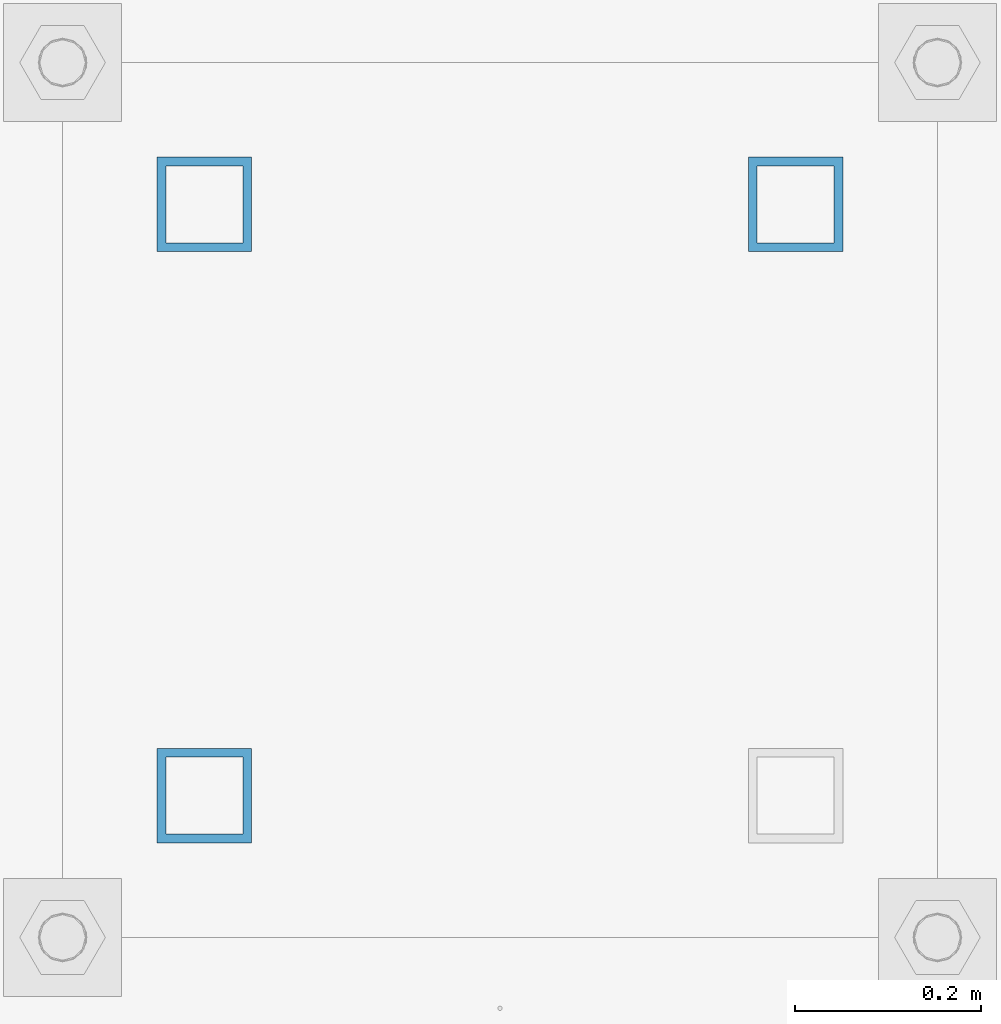
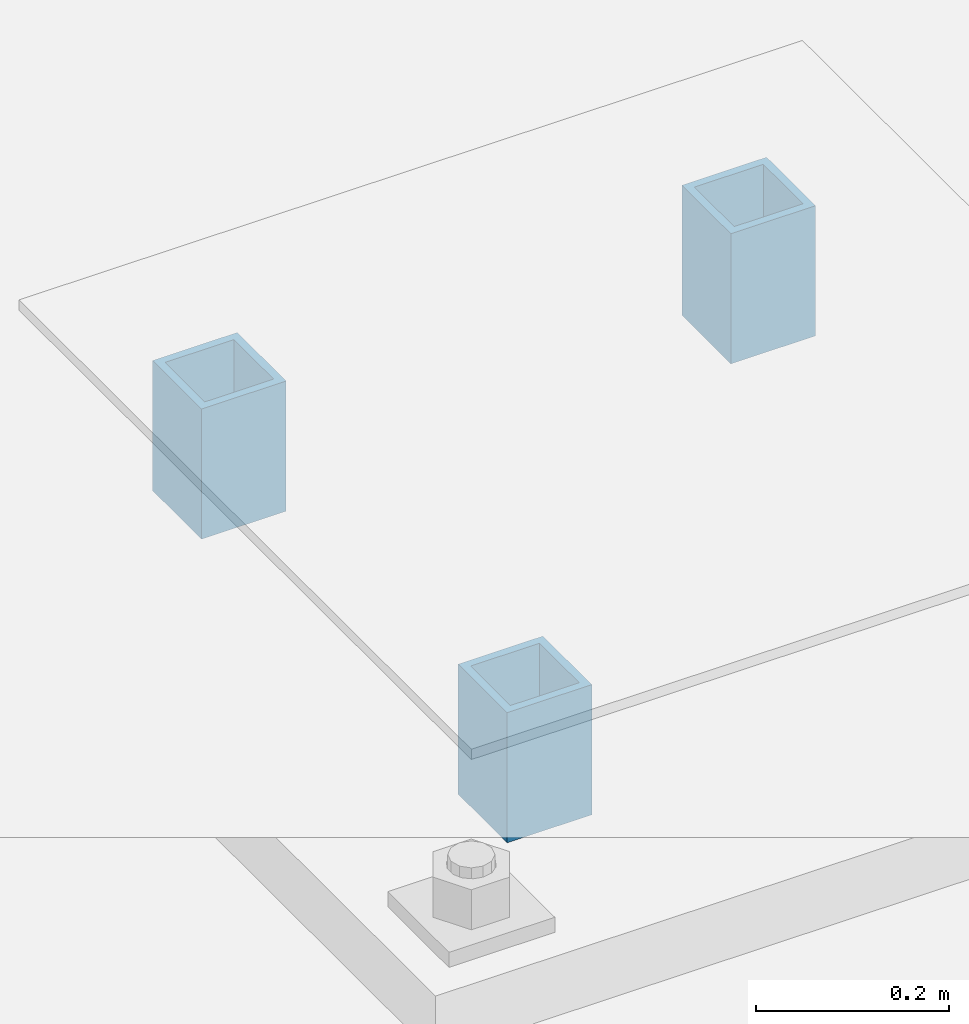
# One storey, part 1623 of 3843: 3 columns, 1 element without a shape of its own.
"""IFC2X3 building model written with IfcOpenShell, lengths in millimetres."""

from ifc_helpers import new_model, si_unit, frame, origin_with_axes, place, context, subcontext, project, spatial, faceted_brep, material, type_object, element, aggregate, save


model = new_model("IFC2X3")

# Units and contexts
model_context = context("Model", 3, precision=1e-05, world=origin_with_axes())
body_context = subcontext(model_context, "Body", "Model", "MODEL_VIEW")
ifc_project = project(units=[si_unit("LENGTHUNIT", "METRE", prefix="MILLI"), si_unit("AREAUNIT", "SQUARE_METRE"), si_unit("VOLUMEUNIT", "CUBIC_METRE"), si_unit("MASSUNIT", "GRAM", prefix="KILO"), si_unit("TIMEUNIT", "SECOND"), si_unit("PLANEANGLEUNIT", "RADIAN"), si_unit("SOLIDANGLEUNIT", "STERADIAN"), si_unit("THERMODYNAMICTEMPERATUREUNIT", "DEGREE_CELSIUS"), si_unit("LUMINOUSINTENSITYUNIT", "LUMEN")], contexts=[model_context])

# Site, building, storey
site_placement = place(None, origin_with_axes())
site = spatial("IfcSite", under=ifc_project, at=site_placement, CompositionType="ELEMENT")
building_placement = place(site_placement, origin_with_axes())
building = spatial("IfcBuilding", under=site, at=building_placement, Name="Undefined", CompositionType="ELEMENT")
storey_placement = place(building_placement, origin_with_axes())
storey = spatial("IfcBuildingStorey", under=building, at=storey_placement, Name="Undefined", CompositionType="ELEMENT", Elevation=0.0)

# Assembly, columns
assembly_placement = place(storey_placement, origin_with_axes())
assembly = element("IfcElementAssembly", 1, at=assembly_placement, inside=storey, Name="EMBED_PLATE", AssemblyPlace="NOTDEFINED", PredefinedType="RIGID_FRAME")
ifc_material = material()
column_type = type_object("IfcColumnType", Name="HSS4X4X3/8", PredefinedType="NOTDEFINED")
column_1_placement = place(assembly_placement, frame((109270.8, 29730.7, 29864.05), z_axis=(0.0, 1.0, 0.0), x_axis=(0.0, 0.0, 1.0)))
column_1 = element("IfcColumn", 2, at=column_1_placement, type_object=column_type, material=ifc_material, Name="POST", ObjectType="HSS4X4X3/8", context=body_context, shape_type="Brep", body=[
    faceted_brep([(0.0, 41.2749999999942, -41.2750000000015), (0.0, -41.2749999999942, -41.2750000000015), (165.099999999999, -41.2749999999942, -41.2750000000015), (165.099999999999, 41.2749999999942, -41.2750000000015), (0.0, -41.2749999999942, 41.2750000000015), (165.099999999999, -41.2749999999942, 41.2750000000015), (0.0, 41.2749999999942, 41.2750000000015), (165.099999999999, 41.2749999999942, 41.2750000000015), (0.0, 50.8000000000029, -50.8000000000029), (0.0, 50.8000000000029, 50.8000000000029), (165.099999999999, 50.8000000000029, 50.8000000000029), (165.099999999999, 50.8000000000029, -50.8000000000029), (0.0, -50.8000000000029, 50.8000000000029), (165.099999999999, -50.8000000000029, 50.8000000000029), (0.0, -50.8000000000029, -50.8000000000029), (165.099999999999, -50.8000000000029, -50.8000000000029)], [[[0, 1, 2, 3]], [[1, 4, 5, 2]], [[4, 6, 7, 5]], [[6, 0, 3, 7]], [[8, 9, 10, 11]], [[9, 12, 13, 10]], [[12, 14, 15, 13]], [[14, 8, 11, 15]], [[13, 15, 11, 10], [5, 7, 3, 2]], [[14, 12, 9, 8], [6, 4, 1, 0]]]),
])
column_2_placement = place(assembly_placement, frame((108635.8, 29095.7, 29864.05), z_axis=(0.0, 1.0, 0.0), x_axis=(0.0, 0.0, 1.0)))
column_2 = element("IfcColumn", 3, at=column_2_placement, type_object=column_type, material=ifc_material, Name="POST", ObjectType="HSS4X4X3/8", context=body_context, shape_type="Brep", body=[
    faceted_brep([(0.0, 41.2749999999942, -41.2750000000015), (0.0, -41.2749999999942, -41.2750000000015), (165.099999999999, -41.2749999999942, -41.2750000000015), (165.099999999999, 41.2749999999942, -41.2750000000015), (0.0, -41.2749999999942, 41.2750000000015), (165.099999999999, -41.2749999999942, 41.2750000000015), (0.0, 41.2749999999942, 41.2750000000015), (165.099999999999, 41.2749999999942, 41.2750000000015), (0.0, 50.8000000000029, -50.8000000000029), (0.0, 50.8000000000029, 50.8000000000029), (165.099999999999, 50.8000000000029, 50.8000000000029), (165.099999999999, 50.8000000000029, -50.8000000000029), (0.0, -50.8000000000029, 50.8000000000029), (165.099999999999, -50.8000000000029, 50.8000000000029), (0.0, -50.8000000000029, -50.8000000000029), (165.099999999999, -50.8000000000029, -50.8000000000029)], [[[0, 1, 2, 3]], [[1, 4, 5, 2]], [[4, 6, 7, 5]], [[6, 0, 3, 7]], [[8, 9, 10, 11]], [[9, 12, 13, 10]], [[12, 14, 15, 13]], [[14, 8, 11, 15]], [[13, 15, 11, 10], [5, 7, 3, 2]], [[14, 12, 9, 8], [6, 4, 1, 0]]]),
])
column_3_placement = place(assembly_placement, frame((108635.8, 29730.7, 29864.05), z_axis=(0.0, 1.0, 0.0), x_axis=(0.0, 0.0, 1.0)))
column_3 = element("IfcColumn", 4, at=column_3_placement, type_object=column_type, material=ifc_material, Name="POST", ObjectType="HSS4X4X3/8", context=body_context, shape_type="Brep", body=[
    faceted_brep([(0.0, 41.2749999999942, -41.2750000000015), (0.0, -41.2749999999942, -41.2750000000015), (165.099999999999, -41.2749999999942, -41.2750000000015), (165.099999999999, 41.2749999999942, -41.2750000000015), (0.0, -41.2749999999942, 41.2750000000015), (165.099999999999, -41.2749999999942, 41.2750000000015), (0.0, 41.2749999999942, 41.2750000000015), (165.099999999999, 41.2749999999942, 41.2750000000015), (0.0, 50.8000000000029, -50.8000000000029), (0.0, 50.8000000000029, 50.8000000000029), (165.099999999999, 50.8000000000029, 50.8000000000029), (165.099999999999, 50.8000000000029, -50.8000000000029), (0.0, -50.8000000000029, 50.8000000000029), (165.099999999999, -50.8000000000029, 50.8000000000029), (0.0, -50.8000000000029, -50.8000000000029), (165.099999999999, -50.8000000000029, -50.8000000000029)], [[[0, 1, 2, 3]], [[1, 4, 5, 2]], [[4, 6, 7, 5]], [[6, 0, 3, 7]], [[8, 9, 10, 11]], [[9, 12, 13, 10]], [[12, 14, 15, 13]], [[14, 8, 11, 15]], [[13, 15, 11, 10], [5, 7, 3, 2]], [[14, 12, 9, 8], [6, 4, 1, 0]]]),
])
aggregate(assembly, [column_1, column_2, column_3])

save(model, "model.ifc")
